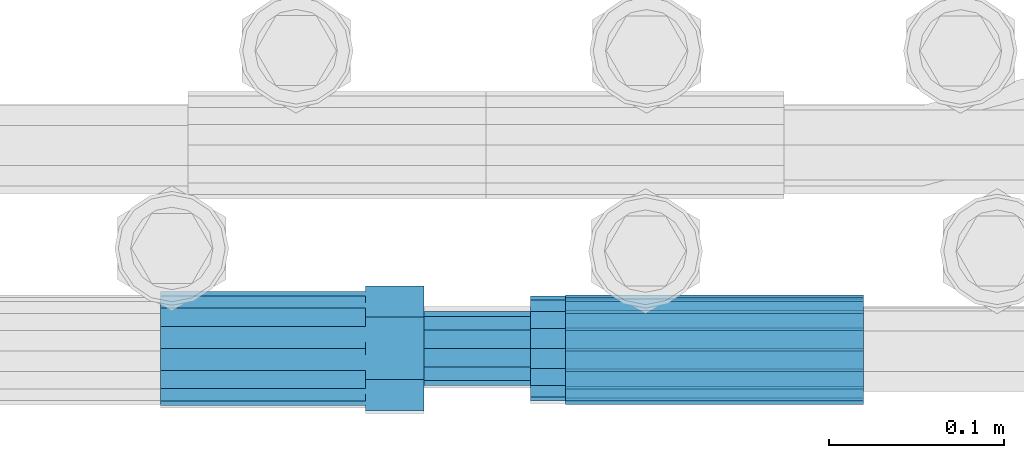
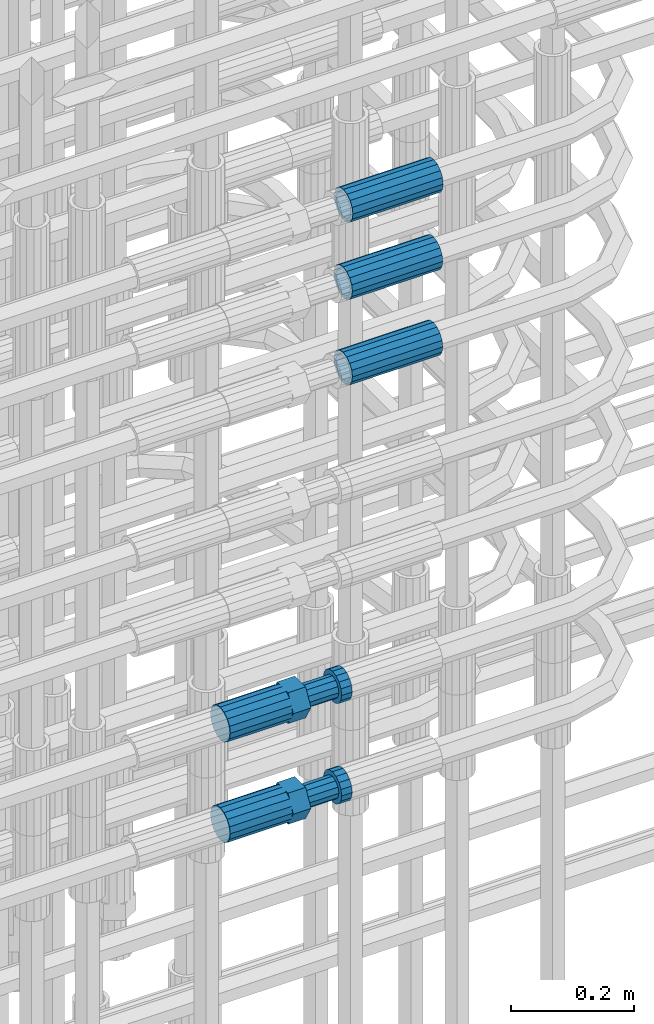
# One storey, part 60 of 119: 5 beams.
"""IFC2X3 building model written with IfcOpenShell, lengths in millimetres."""

from ifc_helpers import new_model, si_unit, frame, origin_with_axes, place, context, subcontext, project, spatial, faceted_brep, material, type_object, element, save


model = new_model("IFC2X3")

# Units and contexts
model_context = context("Model", 3, precision=1e-05, world=origin_with_axes())
body_context = subcontext(model_context, "Body", "Model", "MODEL_VIEW")
ifc_project = project(units=[si_unit("LENGTHUNIT", "METRE", prefix="MILLI"), si_unit("AREAUNIT", "SQUARE_METRE"), si_unit("VOLUMEUNIT", "CUBIC_METRE"), si_unit("MASSUNIT", "GRAM", prefix="KILO"), si_unit("TIMEUNIT", "SECOND"), si_unit("PLANEANGLEUNIT", "RADIAN"), si_unit("SOLIDANGLEUNIT", "STERADIAN"), si_unit("THERMODYNAMICTEMPERATUREUNIT", "DEGREE_CELSIUS"), si_unit("LUMINOUSINTENSITYUNIT", "LUMEN")], contexts=[model_context])

# Site, building, storey
site_placement = place(None, origin_with_axes())
site = spatial("IfcSite", under=ifc_project, at=site_placement, CompositionType="ELEMENT")
building_placement = place(site_placement, origin_with_axes())
building = spatial("IfcBuilding", under=site, at=building_placement, Name="Undefined", CompositionType="ELEMENT")
storey_placement = place(building_placement, origin_with_axes())
storey = spatial("IfcBuildingStorey", under=building, at=storey_placement, Name="Undefined", CompositionType="ELEMENT", Elevation=0.0)

# Beams
ifc_material = material(Name="STEEL/S275")
beam_type_1 = type_object("IfcBeamType", PredefinedType="NOTDEFINED")
beam_1_placement = place(storey_placement, frame((2036249.65345925, 6205098.98577421, 20587.9868409163), z_axis=(0.0, 0.0, 1.0), x_axis=(-0.999999999998145, -1.92600247614167e-06, 0.0)))
element("IfcBeam", 1, at=beam_1_placement, inside=storey, type_object=beam_type_1, material=ifc_material, Name="AG40N", context=body_context, shape_type="Brep", body=[
    faceted_brep([(1.62981450557709e-09, -23.4999999990687, 0.0), (7.45058059692383e-09, -21.7111690142192, 8.99306066057534), (170.000002125278, -21.711168999318, 8.99306066022245), (170.000002127141, -23.4999999844003, -3.66071617463604e-10), (4.65661287307739e-09, -16.6170093587134, 16.6170093578889), (170.000002122484, -16.6170093440451, 16.6170093575288), (1.86264514923096e-09, -8.99306066217832, 21.7111690140277), (170.000002118759, -8.99306064750999, 21.7111690136603), (2.3283064365387e-10, 9.31322574615479e-10, 23.5), (170.000002114102, 1.28056854009628e-08, 23.4999999996485), (-6.51925802230835e-09, 8.99306065868586, 21.7111690140241), (170.00000211224, 8.99306067335419, 21.7111690136639), (-7.45058059692383e-09, 16.6170093561523, 16.6170093578853), (170.000002109446, 16.6170093708206, 16.6170093575324), (-9.31322574615479e-09, 21.711169013055, 8.99306066057534), (170.000002108514, 21.7111690277234, 8.99306066022245), (-1.16415321826935e-09, 23.5000000009313, 0.0), (170.000002108514, 23.5000000144355, -3.66071617463604e-10), (-8.38190317153931e-09, 21.7111690151505, -8.99306066059444), (170.000002110377, 21.7111690300517, -8.9930606609546), (-5.58793544769287e-09, 16.6170093598776, -16.6170093579008), (170.000002113171, 16.6170093745459, -16.6170093582609), (-9.31322574615479e-10, 8.99306066334248, -21.7111690140396), (170.000002115965, 8.99306067801081, -21.7111690143961), (2.3283064365387e-10, 9.31322574615479e-10, -23.5), (170.00000211969, 1.7927959561348e-08, -23.5000000003843), (5.58793544769287e-09, -8.99306065752171, -21.7111690140396), (170.000002123415, -8.99306064285338, -21.7111690143961), (8.38190317153931e-09, -16.6170093549881, -16.6170093579008), (170.000002125278, -16.6170093403198, -16.6170093582646), (9.31322574615479e-09, -21.7111690121237, -8.99306066059444), (170.000002127141, -21.7111689972226, -8.9930606609546), (1.11758708953857e-08, -30.4999999990687, -9.54969436861575e-12), (1.30385160446167e-08, -28.1783257392235, -11.6718446871514), (170.000002129003, -28.1783257243223, -11.6718446875116), (170.000002129935, -30.4999999841675, -3.66071617463604e-10), (1.02445483207703e-08, -21.5667568228673, -21.5667568262129), (170.000002128072, -21.566756808199, -21.5667568265694), (7.45058059692383e-09, -11.6718446831219, -28.1783257416196), (170.000002125278, -11.6718446684536, -28.1783257419834), (3.72529029846191e-09, 3.95812094211578e-09, -30.5000000000277), (170.00000211969, 1.83936208486557e-08, -30.5000000003879), (-9.31322574615479e-10, 11.6718446905725, -28.1783257416232), (170.000002115965, 11.6718447052408, -28.1783257419797), (-6.51925802230835e-09, 21.5667568286881, -21.5667568262093), (170.000002110377, 21.5667568433564, -21.5667568265694), (-9.31322574615479e-09, 28.178325742716, -11.6718446871478), (170.000002108514, 28.1783257573843, -11.6718446875079), (-1.21071934700012e-08, 30.5, -5.91171556152403e-12), (170.000002106652, 30.5000000144355, -3.62433638656512e-10), (-1.21071934700012e-08, 28.1783257401548, 11.6718446871359), (170.00000210572, 28.1783257548232, 11.6718446867794), (-1.02445483207703e-08, 21.5667568240315, 21.5667568261974), (170.000002107583, 21.566756838467, 21.5667568258409), (-7.45058059692383e-09, 11.671844684286, 28.1783257416041), (170.000002110377, 11.6718446989544, 28.178325741244), (-2.79396772384644e-09, -2.56113708019257e-09, 30.5000000000159), (170.000002114102, 1.18743628263474e-08, 30.4999999996558), (1.86264514923096e-09, -11.6718446896411, 28.1783257416114), (170.000002118759, -11.67184467474, 28.178325741244), (7.45058059692383e-09, -21.5667568275239, 21.5667568261974), (170.000002123415, -21.5667568126228, 21.5667568258373), (1.02445483207703e-08, -28.1783257415518, 11.6718446871359), (170.000002127141, -28.1783257271163, 11.6718446867794)], [[[0, 1, 2, 3]], [[1, 4, 5, 2]], [[4, 6, 7, 5]], [[6, 8, 9, 7]], [[8, 10, 11, 9]], [[10, 12, 13, 11]], [[12, 14, 15, 13]], [[14, 16, 17, 15]], [[16, 18, 19, 17]], [[18, 20, 21, 19]], [[20, 22, 23, 21]], [[22, 24, 25, 23]], [[24, 26, 27, 25]], [[26, 28, 29, 27]], [[28, 30, 31, 29]], [[30, 0, 3, 31]], [[32, 33, 34, 35]], [[33, 36, 37, 34]], [[36, 38, 39, 37]], [[38, 40, 41, 39]], [[40, 42, 43, 41]], [[42, 44, 45, 43]], [[44, 46, 47, 45]], [[46, 48, 49, 47]], [[48, 50, 51, 49]], [[50, 52, 53, 51]], [[52, 54, 55, 53]], [[54, 56, 57, 55]], [[56, 58, 59, 57]], [[58, 60, 61, 59]], [[60, 62, 63, 61]], [[62, 32, 35, 63]], [[37, 39, 41, 43, 45, 47, 49, 51, 53, 55, 57, 59, 61, 63, 35, 34], [5, 7, 9, 11, 13, 15, 17, 19, 21, 23, 25, 27, 29, 31, 3, 2]], [[62, 60, 58, 56, 54, 52, 50, 48, 46, 44, 42, 40, 38, 36, 33, 32], [30, 28, 26, 24, 22, 20, 18, 16, 14, 12, 10, 8, 6, 4, 1, 0]]]),
])
beam_2_placement = place(storey_placement, frame((2036249.65345925, 6205098.98577421, 20757.9868409387), z_axis=(0.0, 0.0, 1.0), x_axis=(-0.999999999998145, -1.92600247614167e-06, 0.0)))
element("IfcBeam", 2, at=beam_2_placement, inside=storey, type_object=beam_type_1, material=ifc_material, Name="AG40N", context=body_context, shape_type="Brep", body=[
    faceted_brep([(1.62981450557709e-09, -23.4999999990687, 0.0), (7.45058059692383e-09, -21.7111690142192, 8.99306066057534), (170.000002125278, -21.711168999318, 8.99306066022245), (170.000002127141, -23.4999999844003, -3.66071617463604e-10), (4.65661287307739e-09, -16.6170093587134, 16.6170093578889), (170.000002122484, -16.6170093440451, 16.6170093575288), (1.86264514923096e-09, -8.99306066217832, 21.7111690140277), (170.000002118759, -8.99306064750999, 21.7111690136603), (2.3283064365387e-10, 9.31322574615479e-10, 23.5), (170.000002114102, 1.28056854009628e-08, 23.4999999996485), (-6.51925802230835e-09, 8.99306065868586, 21.7111690140241), (170.00000211224, 8.99306067335419, 21.7111690136639), (-7.45058059692383e-09, 16.6170093561523, 16.6170093578853), (170.000002109446, 16.6170093708206, 16.6170093575324), (-9.31322574615479e-09, 21.711169013055, 8.99306066057534), (170.000002108514, 21.7111690277234, 8.99306066022245), (-1.16415321826935e-09, 23.5000000009313, 0.0), (170.000002108514, 23.5000000144355, -3.66071617463604e-10), (-8.38190317153931e-09, 21.7111690151505, -8.99306066059444), (170.000002110377, 21.7111690300517, -8.9930606609546), (-5.58793544769287e-09, 16.6170093598776, -16.6170093579008), (170.000002113171, 16.6170093745459, -16.6170093582609), (-9.31322574615479e-10, 8.99306066334248, -21.7111690140396), (170.000002115965, 8.99306067801081, -21.7111690143961), (2.3283064365387e-10, 9.31322574615479e-10, -23.5), (170.00000211969, 1.7927959561348e-08, -23.5000000003843), (5.58793544769287e-09, -8.99306065752171, -21.7111690140396), (170.000002123415, -8.99306064285338, -21.7111690143961), (8.38190317153931e-09, -16.6170093549881, -16.6170093579008), (170.000002125278, -16.6170093403198, -16.6170093582646), (9.31322574615479e-09, -21.7111690121237, -8.99306066059444), (170.000002127141, -21.7111689972226, -8.9930606609546), (1.11758708953857e-08, -30.4999999990687, -9.54969436861575e-12), (1.30385160446167e-08, -28.1783257392235, -11.6718446871514), (170.000002129003, -28.1783257243223, -11.6718446875116), (170.000002129935, -30.4999999841675, -3.66071617463604e-10), (1.02445483207703e-08, -21.5667568228673, -21.5667568262129), (170.000002128072, -21.566756808199, -21.5667568265694), (7.45058059692383e-09, -11.6718446831219, -28.1783257416196), (170.000002125278, -11.6718446684536, -28.1783257419834), (3.72529029846191e-09, 3.95812094211578e-09, -30.5000000000277), (170.00000211969, 1.83936208486557e-08, -30.5000000003879), (-9.31322574615479e-10, 11.6718446905725, -28.1783257416232), (170.000002115965, 11.6718447052408, -28.1783257419797), (-6.51925802230835e-09, 21.5667568286881, -21.5667568262093), (170.000002110377, 21.5667568433564, -21.5667568265694), (-9.31322574615479e-09, 28.178325742716, -11.6718446871478), (170.000002108514, 28.1783257573843, -11.6718446875079), (-1.21071934700012e-08, 30.5, -5.91171556152403e-12), (170.000002106652, 30.5000000144355, -3.62433638656512e-10), (-1.21071934700012e-08, 28.1783257401548, 11.6718446871359), (170.00000210572, 28.1783257548232, 11.6718446867794), (-1.02445483207703e-08, 21.5667568240315, 21.5667568261974), (170.000002107583, 21.566756838467, 21.5667568258409), (-7.45058059692383e-09, 11.671844684286, 28.1783257416041), (170.000002110377, 11.6718446989544, 28.178325741244), (-2.79396772384644e-09, -2.56113708019257e-09, 30.5000000000159), (170.000002114102, 1.18743628263474e-08, 30.4999999996558), (1.86264514923096e-09, -11.6718446896411, 28.1783257416114), (170.000002118759, -11.67184467474, 28.178325741244), (7.45058059692383e-09, -21.5667568275239, 21.5667568261974), (170.000002123415, -21.5667568126228, 21.5667568258373), (1.02445483207703e-08, -28.1783257415518, 11.6718446871359), (170.000002127141, -28.1783257271163, 11.6718446867794)], [[[0, 1, 2, 3]], [[1, 4, 5, 2]], [[4, 6, 7, 5]], [[6, 8, 9, 7]], [[8, 10, 11, 9]], [[10, 12, 13, 11]], [[12, 14, 15, 13]], [[14, 16, 17, 15]], [[16, 18, 19, 17]], [[18, 20, 21, 19]], [[20, 22, 23, 21]], [[22, 24, 25, 23]], [[24, 26, 27, 25]], [[26, 28, 29, 27]], [[28, 30, 31, 29]], [[30, 0, 3, 31]], [[32, 33, 34, 35]], [[33, 36, 37, 34]], [[36, 38, 39, 37]], [[38, 40, 41, 39]], [[40, 42, 43, 41]], [[42, 44, 45, 43]], [[44, 46, 47, 45]], [[46, 48, 49, 47]], [[48, 50, 51, 49]], [[50, 52, 53, 51]], [[52, 54, 55, 53]], [[54, 56, 57, 55]], [[56, 58, 59, 57]], [[58, 60, 61, 59]], [[60, 62, 63, 61]], [[62, 32, 35, 63]], [[37, 39, 41, 43, 45, 47, 49, 51, 53, 55, 57, 59, 61, 63, 35, 34], [5, 7, 9, 11, 13, 15, 17, 19, 21, 23, 25, 27, 29, 31, 3, 2]], [[62, 60, 58, 56, 54, 52, 50, 48, 46, 44, 42, 40, 38, 36, 33, 32], [30, 28, 26, 24, 22, 20, 18, 16, 14, 12, 10, 8, 6, 4, 1, 0]]]),
])
beam_3_placement = place(storey_placement, frame((2036249.65345925, 6205097.47577416, 20912.7668409387), z_axis=(0.0, 0.0, 1.0), x_axis=(-0.999999999998145, -1.92600247614167e-06, 0.0)))
element("IfcBeam", 3, at=beam_3_placement, inside=storey, type_object=beam_type_1, material=ifc_material, Name="AG40N", context=body_context, shape_type="Brep", body=[
    faceted_brep([(1.62981450557709e-09, -23.4999999990687, 0.0), (7.45058059692383e-09, -21.7111690142192, 8.99306066057534), (170.000002125278, -21.711168999318, 8.99306066022245), (170.000002127141, -23.4999999844003, -3.66071617463604e-10), (4.65661287307739e-09, -16.6170093587134, 16.6170093578889), (170.000002122484, -16.6170093440451, 16.6170093575288), (1.86264514923096e-09, -8.99306066217832, 21.7111690140277), (170.000002118759, -8.99306064750999, 21.7111690136603), (2.3283064365387e-10, 9.31322574615479e-10, 23.5), (170.000002114102, 1.28056854009628e-08, 23.4999999996485), (-6.51925802230835e-09, 8.99306065868586, 21.7111690140241), (170.00000211224, 8.99306067335419, 21.7111690136639), (-7.45058059692383e-09, 16.6170093561523, 16.6170093578853), (170.000002109446, 16.6170093708206, 16.6170093575324), (-9.31322574615479e-09, 21.711169013055, 8.99306066057534), (170.000002108514, 21.7111690277234, 8.99306066022245), (-1.16415321826935e-09, 23.5000000009313, 0.0), (170.000002108514, 23.5000000144355, -3.66071617463604e-10), (-8.38190317153931e-09, 21.7111690151505, -8.99306066059444), (170.000002110377, 21.7111690300517, -8.9930606609546), (-5.58793544769287e-09, 16.6170093598776, -16.6170093579008), (170.000002113171, 16.6170093745459, -16.6170093582609), (-9.31322574615479e-10, 8.99306066334248, -21.7111690140396), (170.000002115965, 8.99306067801081, -21.7111690143961), (2.3283064365387e-10, 9.31322574615479e-10, -23.5), (170.00000211969, 1.7927959561348e-08, -23.5000000003843), (5.58793544769287e-09, -8.99306065752171, -21.7111690140396), (170.000002123415, -8.99306064285338, -21.7111690143961), (8.38190317153931e-09, -16.6170093549881, -16.6170093579008), (170.000002125278, -16.6170093403198, -16.6170093582646), (9.31322574615479e-09, -21.7111690121237, -8.99306066059444), (170.000002127141, -21.7111689972226, -8.9930606609546), (1.11758708953857e-08, -30.4999999990687, -9.54969436861575e-12), (1.30385160446167e-08, -28.1783257392235, -11.6718446871514), (170.000002129003, -28.1783257243223, -11.6718446875116), (170.000002129935, -30.4999999841675, -3.66071617463604e-10), (1.02445483207703e-08, -21.5667568228673, -21.5667568262129), (170.000002128072, -21.566756808199, -21.5667568265694), (7.45058059692383e-09, -11.6718446831219, -28.1783257416196), (170.000002125278, -11.6718446684536, -28.1783257419834), (3.72529029846191e-09, 3.95812094211578e-09, -30.5000000000277), (170.00000211969, 1.83936208486557e-08, -30.5000000003879), (-9.31322574615479e-10, 11.6718446905725, -28.1783257416232), (170.000002115965, 11.6718447052408, -28.1783257419797), (-6.51925802230835e-09, 21.5667568286881, -21.5667568262093), (170.000002110377, 21.5667568433564, -21.5667568265694), (-9.31322574615479e-09, 28.178325742716, -11.6718446871478), (170.000002108514, 28.1783257573843, -11.6718446875079), (-1.21071934700012e-08, 30.5, -5.91171556152403e-12), (170.000002106652, 30.5000000144355, -3.62433638656512e-10), (-1.21071934700012e-08, 28.1783257401548, 11.6718446871359), (170.00000210572, 28.1783257548232, 11.6718446867794), (-1.02445483207703e-08, 21.5667568240315, 21.5667568261974), (170.000002107583, 21.566756838467, 21.5667568258409), (-7.45058059692383e-09, 11.671844684286, 28.1783257416041), (170.000002110377, 11.6718446989544, 28.178325741244), (-2.79396772384644e-09, -2.56113708019257e-09, 30.5000000000159), (170.000002114102, 1.18743628263474e-08, 30.4999999996558), (1.86264514923096e-09, -11.6718446896411, 28.1783257416114), (170.000002118759, -11.67184467474, 28.178325741244), (7.45058059692383e-09, -21.5667568275239, 21.5667568261974), (170.000002123415, -21.5667568126228, 21.5667568258373), (1.02445483207703e-08, -28.1783257415518, 11.6718446871359), (170.000002127141, -28.1783257271163, 11.6718446867794)], [[[0, 1, 2, 3]], [[1, 4, 5, 2]], [[4, 6, 7, 5]], [[6, 8, 9, 7]], [[8, 10, 11, 9]], [[10, 12, 13, 11]], [[12, 14, 15, 13]], [[14, 16, 17, 15]], [[16, 18, 19, 17]], [[18, 20, 21, 19]], [[20, 22, 23, 21]], [[22, 24, 25, 23]], [[24, 26, 27, 25]], [[26, 28, 29, 27]], [[28, 30, 31, 29]], [[30, 0, 3, 31]], [[32, 33, 34, 35]], [[33, 36, 37, 34]], [[36, 38, 39, 37]], [[38, 40, 41, 39]], [[40, 42, 43, 41]], [[42, 44, 45, 43]], [[44, 46, 47, 45]], [[46, 48, 49, 47]], [[48, 50, 51, 49]], [[50, 52, 53, 51]], [[52, 54, 55, 53]], [[54, 56, 57, 55]], [[56, 58, 59, 57]], [[58, 60, 61, 59]], [[60, 62, 63, 61]], [[62, 32, 35, 63]], [[37, 39, 41, 43, 45, 47, 49, 51, 53, 55, 57, 59, 61, 63, 35, 34], [5, 7, 9, 11, 13, 15, 17, 19, 21, 23, 25, 27, 29, 31, 3, 2]], [[62, 60, 58, 56, 54, 52, 50, 48, 46, 44, 42, 40, 38, 36, 33, 32], [30, 28, 26, 24, 22, 20, 18, 16, 14, 12, 10, 8, 6, 4, 1, 0]]]),
])
beam_type_2 = type_object("IfcBeamType", Name="ROD65", PredefinedType="NOTDEFINED")
beam_4_placement = place(storey_placement, frame((2035848.66023304, 6205098.98994599, 19760.9894151345), z_axis=(0.0, 0.0, 1.0), x_axis=(1.0, 0.0, 0.0)))
element("IfcBeam", 4, at=beam_4_placement, inside=storey, type_object=beam_type_2, material=ifc_material, Name="AGB40", ObjectType="ROD65", context=body_context, shape_type="Brep", body=[
    faceted_brep([(116.999999999069, 17.8249999252148, 30.8738056446964), (116.999999998137, 22.0056957420893, 23.632628078838), (116.999999999069, 12.4372115600854, 30.0260848066173), (116.999999999069, 8.17543111252598, 30.8738056446964), (117.000000000931, -17.8250000746921, 30.8738056446964), (150.200000001118, -17.8250000723638, 30.8738056446964), (150.199999999255, 17.8249999275431, 30.8738056446964), (117.000000000931, -8.17543109622784, 30.8738056446964), (117.000000001863, -22.0056959956419, 23.6326278985034), (117.000000000931, -12.4372115437873, 30.0260848066173), (117.000000001863, -35.6500000746455, -2.18278728425503e-10), (150.200000002049, -35.6500000723172, -2.18278728425503e-10), (117.000000001863, -30.8443149488885, 8.32369080289209), (117.000000001863, -30.8443149488885, -8.32369080355784), (117.000000002794, -32.4999999918509, 0.0), (117.000000000931, -17.8250000746921, -30.873805645133), (150.200000001118, -17.8250000723638, -30.873805645133), (117.000000001863, -22.0056959961075, -23.6326278982269), (117.000000000931, -8.17543109389953, -30.873805645133), (117.000000000931, -12.4372115437873, -30.0260848066173), (116.999999999069, 17.8249999252148, -30.873805645133), (150.199999999255, 17.8249999275431, -30.873805645133), (116.999999999069, 8.17543111019768, -30.873805645133), (116.999999999069, 12.4372115600854, -30.0260848066173), (116.999999998137, 22.005695742555, -23.6326280785652), (116.999999998137, 35.6499999251682, -2.18278728425503e-10), (150.199999998324, 35.6499999277294, -2.18278728425503e-10), (116.999999998137, 30.8443150522653, -8.32369036550881), (116.999999997206, 32.5000000081491, 0.0), (116.999999998137, 30.8443150522653, 8.32369036483942), (1.86264514923096e-09, -22.9809703885112, 22.9809703885621), (1.86264514923096e-09, -30.0260848065373, 12.4372115518672), (117.000000001863, -30.0260847983882, 12.4372115518672), (117.000000001863, -22.9809703803621, 22.9809703885621), (-1.86264514923096e-09, 22.9809703885112, -22.9809703885621), (-1.86264514923096e-09, 30.0260848065373, -12.4372115518672), (116.999999998137, 30.0260848146863, -12.4372115518672), (116.999999998137, 22.9809703966603, -22.9809703885621), (1.86264514923096e-09, -30.0260848065373, -12.4372115518672), (1.86264514923096e-09, -22.9809703885112, -22.9809703885621), (117.000000001863, -22.9809703803621, -22.9809703885621), (117.000000001863, -30.0260847983882, -12.4372115518672), (9.31322574615479e-10, -12.4372115519363, 30.0260848066173), (0.0, 0.0, 32.5), (-9.31322574615479e-10, 12.4372115519363, 30.0260848066173), (-1.86264514923096e-09, 22.9809703885112, 22.9809703885621), (-1.86264514923096e-09, 30.0260848065373, 12.4372115518672), (-2.79396772384644e-09, 32.5, 0.0), (-9.31322574615479e-10, 12.4372115519363, -30.0260848066173), (0.0, 0.0, -32.5), (9.31322574615479e-10, -12.4372115519363, -30.0260848066173), (2.79396772384644e-09, -32.5, 0.0), (116.999999998137, 22.9809703966603, 22.9809703885621), (116.999999998137, 30.0260848146863, 12.4372115518672), (117.0, 8.14907252788544e-09, -32.5), (117.0, 8.14907252788544e-09, 32.5), (150.200000000186, -10.5000000959262, 18.1865334791873), (150.199999999255, -9.59262251853943e-08, 20.9999999997126), (150.199999998324, 10.4999999040738, 18.1865334791873), (150.199999997392, 18.1865333835594, 10.4999999997126), (150.199999997392, 20.9999999040738, -2.87400325760245e-10), (150.199999997392, 18.1865333835594, -10.5000000002874), (150.199999998324, 10.4999999040738, -18.1865334797621), (150.199999999255, -9.59262251853943e-08, -21.0000000002874), (150.200000000186, -10.5000000959262, -18.1865334797621), (150.200000000186, -18.1865335754119, -10.5000000002874), (150.200000001118, -21.0000000959262, -2.87400325760245e-10), (150.200000000186, -18.1865335754119, 10.4999999997126), (210.979999999516, 10.4999999082647, 18.1865334791873), (210.979999999516, -9.17352735996246e-08, 20.9999999997126), (210.979999997653, 18.1865333877504, 10.4999999997126), (210.979999997653, 20.9999999082647, -2.87400325760245e-10), (210.979999997653, 18.1865333877504, -10.5000000002874), (210.979999999516, 10.4999999082647, -18.1865334797621), (210.979999999516, -9.17352735996246e-08, -21.0000000002874), (210.979999999516, -10.5000000917353, -18.1865334797621), (210.980000000447, -18.1865335712209, -10.5000000002874), (210.980000001378, -21.0000000917353, -2.87400325760245e-10), (210.980000000447, -18.1865335712209, 10.4999999997126), (210.979999999516, -10.5000000917353, 18.1865334791873), (211.001368402503, -27.7269939335529, -11.4911163272045), (211.003082515672, -21.2238095656503, -21.2238154190527), (231.002518340945, -21.2131946226582, -21.2132004554769), (231.000804228708, -27.7163789905608, -11.4805013636287), (211.001368415542, -11.4911086384673, -27.7269970399575), (231.000804241747, -11.4804936954752, -27.7163820763781), (210.996487061493, -0.0106066407170147, -30.0106107396168), (230.995922887698, 8.30227509140968e-06, -29.999995776041), (210.98918159306, 11.4698940692469, -27.7269970332745), (230.988617419265, 11.4805090120062, -27.7163820696951), (210.980564201251, 21.2025913291145, -21.2238154067054), (230.980000027455, 21.2132062721066, -21.2132004431296), (210.971946807578, 27.7057702087332, -11.4911163110701), (230.971382633783, 27.7163851517253, -11.4805013474943), (210.964641331695, 29.9893806746695, -0.0106149565435771), (230.9640771579, 29.9999956176616, 7.03221303410828e-09), (210.959759964608, 27.7057637346443, 11.4698863966551), (230.959195790812, 27.7163786776364, 11.4805013602345), (210.958045851439, 21.2025793667417, 21.2025854885032), (230.957481677644, 21.2131943097338, 21.2132004520827), (210.959759951569, 11.4698784395587, 27.705767109408), (230.959195776843, 11.4804933823179, 27.7163820729838), (210.964641305618, -0.0106235581915826, 29.9893808090674), (230.964077131823, -8.61519947648048e-06, 29.9999957726432), (210.971946774051, -11.4911242681555, 27.7057671027251), (230.971382599324, -11.4805093251634, 27.7163820663009), (210.98056416586, -21.2238215280231, 21.2025854761559), (230.979999991134, -21.2132065852638, 21.2132004397354), (210.989181559533, -27.7270004076418, 11.4698863805206), (230.988617384806, -27.7163854646496, 11.4805013441), (210.996487035416, -30.0106108735781, -0.0106149740058754), (230.995922861621, -29.999995930586, -1.04300852399319e-08)], [[[0, 1, 2, 3]], [[4, 5, 6, 0, 3, 7]], [[8, 4, 7, 9]], [[10, 11, 5, 4, 8, 12]], [[13, 10, 12, 14]], [[15, 16, 11, 10, 13, 17]], [[18, 15, 17, 19]], [[20, 21, 16, 15, 18, 22]], [[20, 22, 23, 24]], [[25, 26, 21, 20, 24, 27]], [[25, 27, 28, 29]], [[30, 31, 32, 33]], [[34, 35, 36, 37]], [[38, 39, 40, 41]], [[31, 30, 42, 43, 44, 45, 46, 47, 35, 34, 48, 49, 50, 39, 38, 51]], [[46, 45, 52, 53]], [[28, 47, 46, 53, 29]], [[27, 36, 35, 47, 28]], [[24, 37, 36, 27]], [[23, 48, 34, 37, 24]], [[22, 54, 49, 48, 23]], [[18, 54, 22]], [[19, 50, 49, 54, 18]], [[17, 40, 39, 50, 19]], [[13, 41, 40, 17]], [[14, 51, 38, 41, 13]], [[12, 32, 31, 51, 14]], [[8, 33, 32, 12]], [[9, 42, 30, 33, 8]], [[7, 55, 43, 42, 9]], [[3, 55, 7]], [[2, 44, 43, 55, 3]], [[1, 52, 45, 44, 2]], [[29, 53, 52, 1]], [[0, 6, 26, 25, 29, 1]], [[5, 11, 16, 21, 26, 6], [56, 57, 58, 59, 60, 61, 62, 63, 64, 65, 66, 67]], [[68, 58, 57, 69]], [[70, 59, 58, 68]], [[71, 60, 59, 70]], [[72, 61, 60, 71]], [[73, 62, 61, 72]], [[74, 63, 62, 73]], [[75, 64, 63, 74]], [[76, 65, 64, 75]], [[77, 66, 65, 76]], [[78, 67, 66, 77]], [[79, 56, 67, 78]], [[69, 57, 56, 79]], [[80, 81, 82, 83]], [[81, 84, 85, 82]], [[84, 86, 87, 85]], [[86, 88, 89, 87]], [[88, 90, 91, 89]], [[90, 92, 93, 91]], [[92, 94, 95, 93]], [[94, 96, 97, 95]], [[96, 98, 99, 97]], [[98, 100, 101, 99]], [[100, 102, 103, 101]], [[102, 104, 105, 103]], [[104, 106, 107, 105]], [[106, 108, 109, 107]], [[108, 110, 111, 109]], [[82, 85, 87, 89, 91, 93, 95, 97, 99, 101, 103, 105, 107, 109, 111, 83]], [[110, 80, 83, 111]], [[108, 106, 104, 102, 100, 98, 96, 94, 92, 90, 88, 86, 84, 81, 80, 110], [78, 77, 76, 75, 74, 73, 72, 71, 70, 68, 69, 79]]]),
])
beam_5_placement = place(storey_placement, frame((2035848.66023304, 6205098.98994599, 19960.9894151345), z_axis=(0.0, 0.0, 1.0), x_axis=(1.0, 0.0, 0.0)))
element("IfcBeam", 5, at=beam_5_placement, inside=storey, type_object=beam_type_2, material=ifc_material, Name="AGB40", ObjectType="ROD65", context=body_context, shape_type="Brep", body=[
    faceted_brep([(116.999999999069, 17.8249999252148, 30.8738056446964), (116.999999998137, 22.0056957420893, 23.632628078838), (116.999999999069, 12.4372115600854, 30.0260848066173), (116.999999999069, 8.17543111252598, 30.8738056446964), (117.000000000931, -17.8250000746921, 30.8738056446964), (150.200000001118, -17.8250000723638, 30.8738056446964), (150.199999999255, 17.8249999275431, 30.8738056446964), (117.000000000931, -8.17543109622784, 30.8738056446964), (117.000000001863, -22.0056959956419, 23.6326278985034), (117.000000000931, -12.4372115437873, 30.0260848066173), (117.000000001863, -35.6500000746455, -2.18278728425503e-10), (150.200000002049, -35.6500000723172, -2.18278728425503e-10), (117.000000001863, -30.8443149488885, 8.32369080289209), (117.000000001863, -30.8443149488885, -8.32369080355784), (117.000000002794, -32.4999999918509, 0.0), (117.000000000931, -17.8250000746921, -30.873805645133), (150.200000001118, -17.8250000723638, -30.873805645133), (117.000000001863, -22.0056959961075, -23.6326278982269), (117.000000000931, -8.17543109389953, -30.873805645133), (117.000000000931, -12.4372115437873, -30.0260848066173), (116.999999999069, 17.8249999252148, -30.873805645133), (150.199999999255, 17.8249999275431, -30.873805645133), (116.999999999069, 8.17543111019768, -30.873805645133), (116.999999999069, 12.4372115600854, -30.0260848066173), (116.999999998137, 22.005695742555, -23.6326280785652), (116.999999998137, 35.6499999251682, -2.18278728425503e-10), (150.199999998324, 35.6499999277294, -2.18278728425503e-10), (116.999999998137, 30.8443150522653, -8.32369036550881), (116.999999997206, 32.5000000081491, 0.0), (116.999999998137, 30.8443150522653, 8.32369036483942), (1.86264514923096e-09, -22.9809703885112, 22.9809703885621), (1.86264514923096e-09, -30.0260848065373, 12.4372115518672), (117.000000001863, -30.0260847983882, 12.4372115518672), (117.000000001863, -22.9809703803621, 22.9809703885621), (-1.86264514923096e-09, 22.9809703885112, -22.9809703885621), (-1.86264514923096e-09, 30.0260848065373, -12.4372115518672), (116.999999998137, 30.0260848146863, -12.4372115518672), (116.999999998137, 22.9809703966603, -22.9809703885621), (1.86264514923096e-09, -30.0260848065373, -12.4372115518672), (1.86264514923096e-09, -22.9809703885112, -22.9809703885621), (117.000000001863, -22.9809703803621, -22.9809703885621), (117.000000001863, -30.0260847983882, -12.4372115518672), (9.31322574615479e-10, -12.4372115519363, 30.0260848066173), (0.0, 0.0, 32.5), (-9.31322574615479e-10, 12.4372115519363, 30.0260848066173), (-1.86264514923096e-09, 22.9809703885112, 22.9809703885621), (-1.86264514923096e-09, 30.0260848065373, 12.4372115518672), (-2.79396772384644e-09, 32.5, 0.0), (-9.31322574615479e-10, 12.4372115519363, -30.0260848066173), (0.0, 0.0, -32.5), (9.31322574615479e-10, -12.4372115519363, -30.0260848066173), (2.79396772384644e-09, -32.5, 0.0), (116.999999998137, 22.9809703966603, 22.9809703885621), (116.999999998137, 30.0260848146863, 12.4372115518672), (117.0, 8.14907252788544e-09, -32.5), (117.0, 8.14907252788544e-09, 32.5), (150.200000000186, -10.5000000959262, 18.1865334791873), (150.199999999255, -9.59262251853943e-08, 20.9999999997126), (150.199999998324, 10.4999999040738, 18.1865334791873), (150.199999997392, 18.1865333835594, 10.4999999997126), (150.199999997392, 20.9999999040738, -2.87400325760245e-10), (150.199999997392, 18.1865333835594, -10.5000000002874), (150.199999998324, 10.4999999040738, -18.1865334797621), (150.199999999255, -9.59262251853943e-08, -21.0000000002874), (150.200000000186, -10.5000000959262, -18.1865334797621), (150.200000000186, -18.1865335754119, -10.5000000002874), (150.200000001118, -21.0000000959262, -2.87400325760245e-10), (150.200000000186, -18.1865335754119, 10.4999999997126), (210.979999999516, 10.4999999082647, 18.1865334791873), (210.979999999516, -9.17352735996246e-08, 20.9999999997126), (210.979999997653, 18.1865333877504, 10.4999999997126), (210.979999997653, 20.9999999082647, -2.87400325760245e-10), (210.979999997653, 18.1865333877504, -10.5000000002874), (210.979999999516, 10.4999999082647, -18.1865334797621), (210.979999999516, -9.17352735996246e-08, -21.0000000002874), (210.979999999516, -10.5000000917353, -18.1865334797621), (210.980000000447, -18.1865335712209, -10.5000000002874), (210.980000001378, -21.0000000917353, -2.87400325760245e-10), (210.980000000447, -18.1865335712209, 10.4999999997126), (210.979999999516, -10.5000000917353, 18.1865334791873), (211.001368402503, -27.7269939335529, -11.4911163272045), (211.003082515672, -21.2238095656503, -21.2238154190527), (231.002518340945, -21.2131946226582, -21.2132004554769), (231.000804228708, -27.7163789905608, -11.4805013636287), (211.001368415542, -11.4911086384673, -27.7269970399575), (231.000804241747, -11.4804936954752, -27.7163820763781), (210.996487061493, -0.0106066407170147, -30.0106107396168), (230.995922887698, 8.30227509140968e-06, -29.999995776041), (210.98918159306, 11.4698940692469, -27.7269970332745), (230.988617419265, 11.4805090120062, -27.7163820696951), (210.980564201251, 21.2025913291145, -21.2238154067054), (230.980000027455, 21.2132062721066, -21.2132004431296), (210.971946807578, 27.7057702087332, -11.4911163110701), (230.971382633783, 27.7163851517253, -11.4805013474943), (210.964641331695, 29.9893806746695, -0.0106149565435771), (230.9640771579, 29.9999956176616, 7.03221303410828e-09), (210.959759964608, 27.7057637346443, 11.4698863966551), (230.959195790812, 27.7163786776364, 11.4805013602345), (210.958045851439, 21.2025793667417, 21.2025854885032), (230.957481677644, 21.2131943097338, 21.2132004520827), (210.959759951569, 11.4698784395587, 27.705767109408), (230.959195776843, 11.4804933823179, 27.7163820729838), (210.964641305618, -0.0106235581915826, 29.9893808090674), (230.964077131823, -8.61519947648048e-06, 29.9999957726432), (210.971946774051, -11.4911242681555, 27.7057671027251), (230.971382599324, -11.4805093251634, 27.7163820663009), (210.98056416586, -21.2238215280231, 21.2025854761559), (230.979999991134, -21.2132065852638, 21.2132004397354), (210.989181559533, -27.7270004076418, 11.4698863805206), (230.988617384806, -27.7163854646496, 11.4805013441), (210.996487035416, -30.0106108735781, -0.0106149740058754), (230.995922861621, -29.999995930586, -1.04300852399319e-08)], [[[0, 1, 2, 3]], [[4, 5, 6, 0, 3, 7]], [[8, 4, 7, 9]], [[10, 11, 5, 4, 8, 12]], [[13, 10, 12, 14]], [[15, 16, 11, 10, 13, 17]], [[18, 15, 17, 19]], [[20, 21, 16, 15, 18, 22]], [[20, 22, 23, 24]], [[25, 26, 21, 20, 24, 27]], [[25, 27, 28, 29]], [[30, 31, 32, 33]], [[34, 35, 36, 37]], [[38, 39, 40, 41]], [[31, 30, 42, 43, 44, 45, 46, 47, 35, 34, 48, 49, 50, 39, 38, 51]], [[46, 45, 52, 53]], [[28, 47, 46, 53, 29]], [[27, 36, 35, 47, 28]], [[24, 37, 36, 27]], [[23, 48, 34, 37, 24]], [[22, 54, 49, 48, 23]], [[18, 54, 22]], [[19, 50, 49, 54, 18]], [[17, 40, 39, 50, 19]], [[13, 41, 40, 17]], [[14, 51, 38, 41, 13]], [[12, 32, 31, 51, 14]], [[8, 33, 32, 12]], [[9, 42, 30, 33, 8]], [[7, 55, 43, 42, 9]], [[3, 55, 7]], [[2, 44, 43, 55, 3]], [[1, 52, 45, 44, 2]], [[29, 53, 52, 1]], [[0, 6, 26, 25, 29, 1]], [[5, 11, 16, 21, 26, 6], [56, 57, 58, 59, 60, 61, 62, 63, 64, 65, 66, 67]], [[68, 58, 57, 69]], [[70, 59, 58, 68]], [[71, 60, 59, 70]], [[72, 61, 60, 71]], [[73, 62, 61, 72]], [[74, 63, 62, 73]], [[75, 64, 63, 74]], [[76, 65, 64, 75]], [[77, 66, 65, 76]], [[78, 67, 66, 77]], [[79, 56, 67, 78]], [[69, 57, 56, 79]], [[80, 81, 82, 83]], [[81, 84, 85, 82]], [[84, 86, 87, 85]], [[86, 88, 89, 87]], [[88, 90, 91, 89]], [[90, 92, 93, 91]], [[92, 94, 95, 93]], [[94, 96, 97, 95]], [[96, 98, 99, 97]], [[98, 100, 101, 99]], [[100, 102, 103, 101]], [[102, 104, 105, 103]], [[104, 106, 107, 105]], [[106, 108, 109, 107]], [[108, 110, 111, 109]], [[82, 85, 87, 89, 91, 93, 95, 97, 99, 101, 103, 105, 107, 109, 111, 83]], [[110, 80, 83, 111]], [[108, 106, 104, 102, 100, 98, 96, 94, 92, 90, 88, 86, 84, 81, 80, 110], [78, 77, 76, 75, 74, 73, 72, 71, 70, 68, 69, 79]]]),
])

save(model, "model.ifc")
